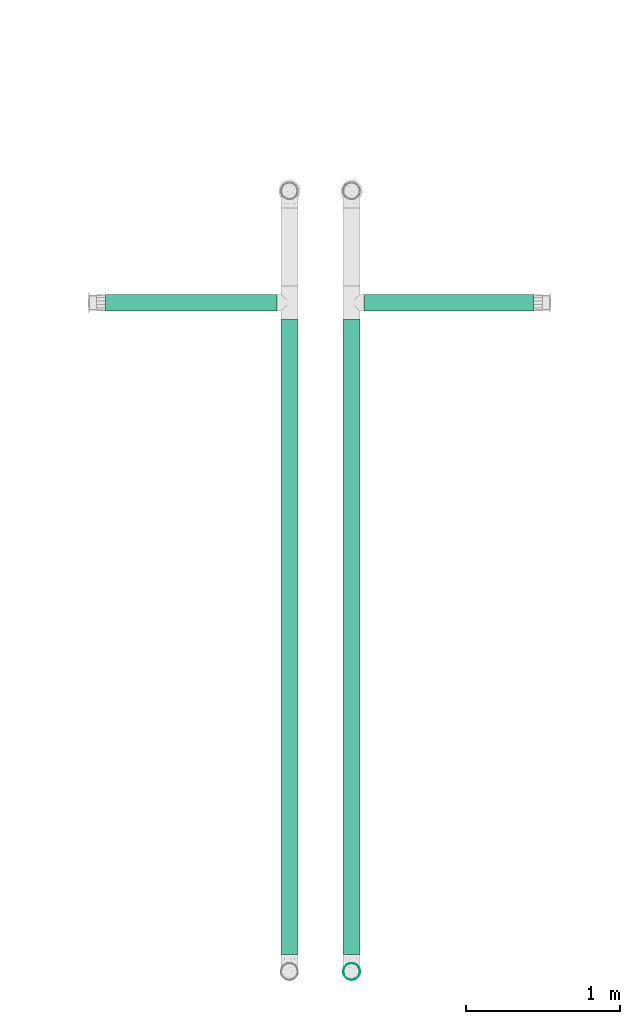
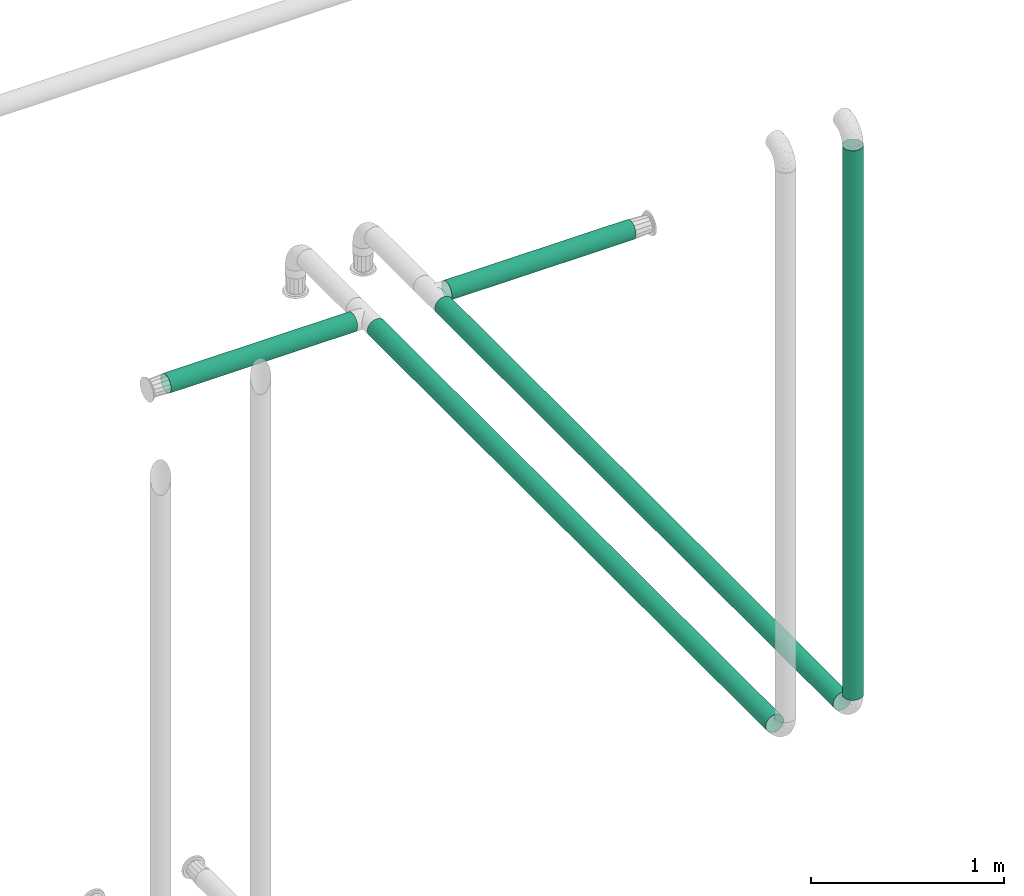
# One storey, part 2 of 115: 5 flow segments.
"""IFC2X3 building model written with IfcOpenShell, lengths in millimetres."""

from ifc_helpers import new_model, entity, si_unit, converted_unit, derived_unit, direction, frame, origin_with_axes, origin_2d_with_axis, place, context, subcontext, project, spatial, hollow_circle, extrude, source, transform, mapped, material, layer, layer_set, layer_usage, type_object, element, save


model = new_model("IFC2X3")

# Units and contexts
model_context = context("Model", 3, precision=1e-05, world=origin_with_axes(), true_north=direction((0.0, 1.0)))
body_context = subcontext(model_context, "Body", "Model", "MODEL_VIEW")
ifc_project = project(units=[si_unit("AREAUNIT", "SQUARE_METRE"), si_unit("VOLUMEUNIT", "CUBIC_METRE", prefix="DECI"), si_unit("TIMEUNIT", "SECOND"), si_unit("THERMODYNAMICTEMPERATUREUNIT", "DEGREE_CELSIUS"), si_unit("PRESSUREUNIT", "PASCAL"), si_unit("MASSUNIT", "GRAM", prefix="KILO"), si_unit("LENGTHUNIT", "METRE", prefix="MILLI"), si_unit("POWERUNIT", "WATT"), si_unit("ELECTRICCURRENTUNIT", "AMPERE"), si_unit("ELECTRICVOLTAGEUNIT", "VOLT"), derived_unit("VOLUMETRICFLOWRATEUNIT", [(si_unit("VOLUMEUNIT", "CUBIC_METRE", prefix="DECI"), 1), (si_unit("TIMEUNIT", "SECOND"), -1)]), derived_unit("LINEARVELOCITYUNIT", [(si_unit("LENGTHUNIT", "METRE"), 1), (si_unit("TIMEUNIT", "SECOND"), -1)]), derived_unit("MASSDENSITYUNIT", [(si_unit("MASSUNIT", "GRAM", prefix="KILO"), 1), (si_unit("VOLUMEUNIT", "CUBIC_METRE"), -1)]), converted_unit("PLANEANGLEUNIT", "DEGREE", entity("IfcRatioMeasure", 0.01745), si_unit("PLANEANGLEUNIT", "RADIAN"), dimensions=[0, 0, 0, 0, 0, 0, 0])], contexts=[model_context])

# Site, building, storey
site_placement = place(None, origin_with_axes())
site = spatial("IfcSite", under=ifc_project, at=site_placement, CompositionType="ELEMENT")
building_placement = place(site_placement, origin_with_axes())
building = spatial("IfcBuilding", under=site, at=building_placement, Name="mc-building", CompositionType="ELEMENT")
storey_placement = place(building_placement, frame((0.0, 0.0, 2950.0), z_axis=(0.0, 0.0, 1.0), x_axis=(1.0, 0.0, 0.0)))
storey = spatial("IfcBuildingStorey", under=building, at=storey_placement, Name="2. Korrus", CompositionType="ELEMENT", Elevation=2950.0)

# Flow segments
ifc_material = material(Name="FZ1")
ifc_layer = layer(ifc_material, 0.0)
ifc_layer_set = layer_set([ifc_layer], Name="FZ1")
ifc_layer_usage = layer_usage(ifc_layer_set, "AXIS1", "POSITIVE", 0.0)
duct_segment_type = type_object("IfcDuctSegmentType", PredefinedType="RIGIDSEGMENT")
shared_shape_1 = source(origin_with_axes(), body_context, "Body", "SweptSolid", [
    extrude(hollow_circle(Radius=55.0, WallThickness=2.0, at=origin_2d_with_axis()), frame((0.0, 0.0, 0.0), z_axis=(1.0, 0.0, 0.0), x_axis=(0.0, 1.0, 0.0)), (0.0, 0.0, 1.0), 3480.0),
])
flow_segment_1_placement = place(storey_placement, frame((16200.78197, -687.64676, 2575.0), z_axis=(1.0, 0.0, 0.0), x_axis=(0.0, 0.0, 1.0)))
element("IfcFlowSegment", 1, at=flow_segment_1_placement, inside=storey, type_object=duct_segment_type, material=ifc_layer_usage, context=body_context, shape_type="MappedRepresentation", body=[
    mapped(shared_shape_1, transform((0.0, 0.0, 0.0), scale=1.0)),
])
shared_shape_2 = source(origin_with_axes(), body_context, "Body", "SweptSolid", [
    extrude(hollow_circle(Radius=55.0, WallThickness=2.0, at=origin_2d_with_axis()), frame((0.0, 0.0, 0.0), z_axis=(1.0, 0.0, 0.0), x_axis=(0.0, 1.0, 0.0)), (0.0, 0.0, 1.0), 4133.9),
])
for number, where, z_axis, x_axis in (
    (2, (15796.4103, -577.64676, 2465.0), (0.0, 0.0, 1.0), (0.0, 1.0, 0.0)),
    (3, (16200.78197, -577.64676, 2465.0), (0.0, 0.0, 1.0), (0.0, 1.0, 0.0)),
):
    element("IfcFlowSegment", number, at=place(storey_placement, frame(where, z_axis=z_axis, x_axis=x_axis)), inside=storey, type_object=duct_segment_type, material=ifc_layer_usage, context=body_context, shape_type="MappedRepresentation", body=[
        mapped(shared_shape_2, transform((0.0, 0.0, 0.0), scale=1.0)),
    ])
shared_shape_3 = source(origin_with_axes(), body_context, "Body", "SweptSolid", [
    extrude(hollow_circle(Radius=55.0, WallThickness=2.0, at=origin_2d_with_axis()), frame((0.0, 0.0, 0.0), z_axis=(1.0, 0.0, 0.0), x_axis=(0.0, 1.0, 0.0)), (0.0, 0.0, 1.0), 1117.3),
])
flow_segment_2_placement = place(storey_placement, frame((15716.4103, 3666.26111, 2465.0), z_axis=(0.0, 0.0, 1.0), x_axis=(-1.0, 0.0, 0.0)))
element("IfcFlowSegment", 4, at=flow_segment_2_placement, inside=storey, type_object=duct_segment_type, material=ifc_layer_usage, context=body_context, shape_type="MappedRepresentation", body=[
    mapped(shared_shape_3, transform((0.0, 0.0, 0.0), scale=1.0)),
])
shared_shape_4 = source(origin_with_axes(), body_context, "Body", "SweptSolid", [
    extrude(hollow_circle(Radius=55.0, WallThickness=2.0, at=origin_2d_with_axis()), frame((0.0, 0.0, 0.0), z_axis=(1.0, 0.0, 0.0), x_axis=(0.0, 1.0, 0.0)), (0.0, 0.0, 1.0), 1104.1),
])
flow_segment_3_placement = place(storey_placement, frame((16280.78197, 3666.26111, 2465.0), z_axis=(0.0, 0.0, 1.0), x_axis=(1.0, 0.0, 0.0)))
element("IfcFlowSegment", 5, at=flow_segment_3_placement, inside=storey, type_object=duct_segment_type, material=ifc_layer_usage, context=body_context, shape_type="MappedRepresentation", body=[
    mapped(shared_shape_4, transform((0.0, 0.0, 0.0), scale=1.0)),
])

save(model, "model.ifc")
